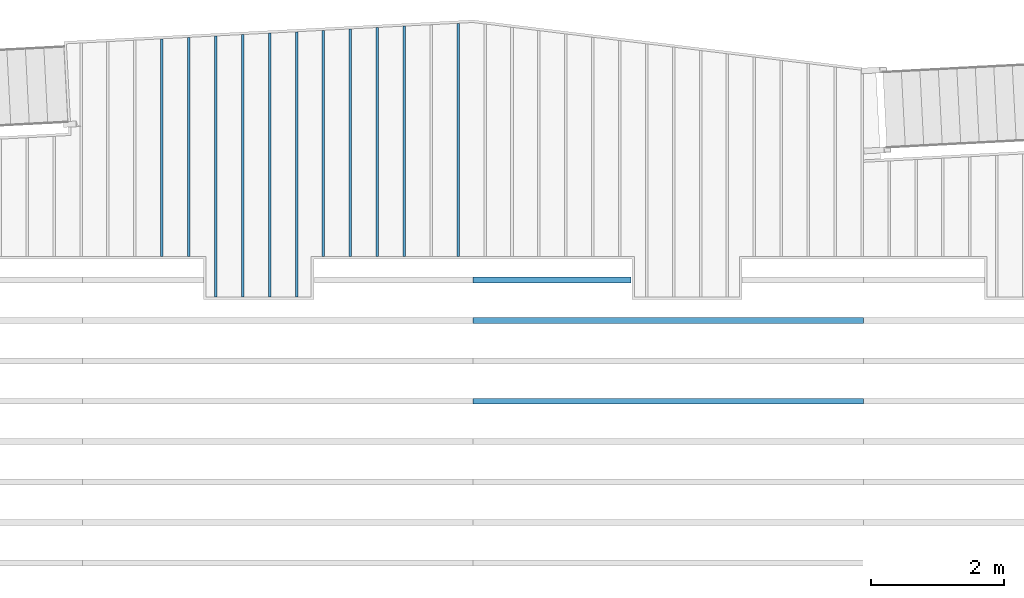
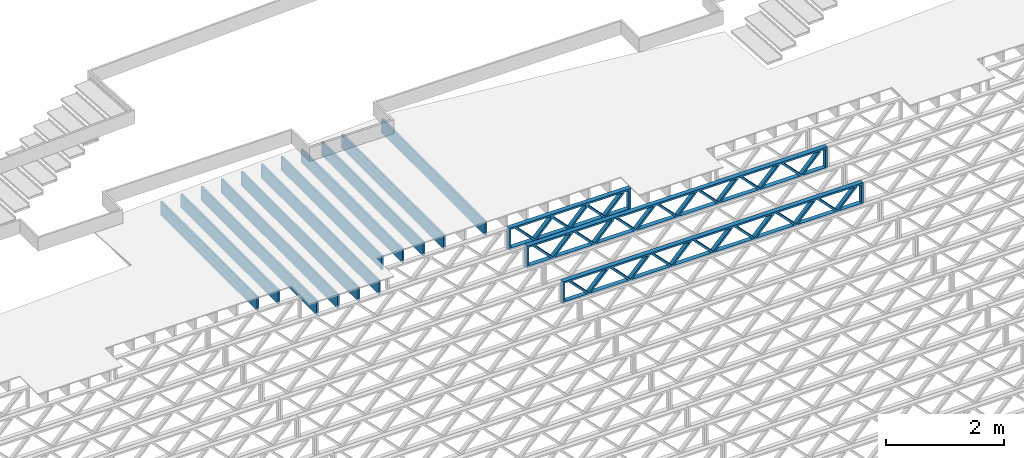
# One storey, part 8 of 23: 14 beams, 2 elements without a shape of their own.
"""IFC4 building model written with IfcOpenShell, lengths in feet."""

from ifc_helpers import new_model, entity, si_unit, converted_unit, derived_unit, direction, frame, frame_2d, origin, origin_2d_with_axis, place, context, subcontext, project, spatial, rectangle, extrude, source, transform, mapped, material, material_profile, profile_set, profile_usage, type_object, type_shapes, element, aggregate, save


model = new_model("IFC4")

# Units and contexts
model_context_1 = context("Model", 3, precision=0.0001, world=origin(), true_north=direction((6.12303176911189e-17, 1.0)))
model_context_2 = context("Model", 3, precision=0.0001, world=origin(), true_north=direction((6.12303176911189e-17, 1.0)))
body_context = subcontext(model_context_2, "Body", "Model", "MODEL_VIEW")
ifc_project = project(units=[converted_unit("LENGTHUNIT", "FOOT", entity("IfcRatioMeasure", 0.3048), si_unit("LENGTHUNIT", "METRE"), dimensions=[1, 0, 0, 0, 0, 0, 0]), converted_unit("AREAUNIT", "SQUARE FOOT", entity("IfcRatioMeasure", 0.09290304), si_unit("AREAUNIT", "SQUARE_METRE"), dimensions=[2, 0, 0, 0, 0, 0, 0]), converted_unit("VOLUMEUNIT", "CUBIC FOOT", entity("IfcRatioMeasure", 0.028316846592), si_unit("VOLUMEUNIT", "CUBIC_METRE"), dimensions=[3, 0, 0, 0, 0, 0, 0]), converted_unit("PLANEANGLEUNIT", "DEGREE", entity("IfcRatioMeasure", 0.0174532925199433), si_unit("PLANEANGLEUNIT", "RADIAN"), dimensions=[0, 0, 0, 0, 0, 0, 0]), si_unit("MASSUNIT", "GRAM", prefix="KILO"), derived_unit("MASSDENSITYUNIT", [(si_unit("MASSUNIT", "GRAM", prefix="KILO"), 1), (si_unit("LENGTHUNIT", "METRE"), -3)]), derived_unit("MOMENTOFINERTIAUNIT", [(si_unit("LENGTHUNIT", "METRE"), 4)]), si_unit("TIMEUNIT", "SECOND"), si_unit("FREQUENCYUNIT", "HERTZ"), si_unit("THERMODYNAMICTEMPERATUREUNIT", "DEGREE_CELSIUS"), derived_unit("THERMALTRANSMITTANCEUNIT", [(si_unit("MASSUNIT", "GRAM", prefix="KILO"), 1), (si_unit("THERMODYNAMICTEMPERATUREUNIT", "KELVIN"), -1), (si_unit("TIMEUNIT", "SECOND"), -3)]), derived_unit("VOLUMETRICFLOWRATEUNIT", [(si_unit("LENGTHUNIT", "METRE"), 3), (si_unit("TIMEUNIT", "SECOND"), -1)]), si_unit("ELECTRICCURRENTUNIT", "AMPERE"), si_unit("ELECTRICVOLTAGEUNIT", "VOLT"), si_unit("POWERUNIT", "WATT"), si_unit("FORCEUNIT", "NEWTON"), si_unit("ILLUMINANCEUNIT", "LUX"), si_unit("LUMINOUSFLUXUNIT", "LUMEN"), si_unit("LUMINOUSINTENSITYUNIT", "CANDELA"), derived_unit("USERDEFINED", [(si_unit("MASSUNIT", "GRAM", prefix="KILO"), -1), (si_unit("LENGTHUNIT", "METRE"), -2), (si_unit("TIMEUNIT", "SECOND"), 3), (si_unit("LUMINOUSFLUXUNIT", "LUMEN"), 1)]), derived_unit("LINEARVELOCITYUNIT", [(si_unit("LENGTHUNIT", "METRE"), 1), (si_unit("TIMEUNIT", "SECOND"), -1)]), si_unit("PRESSUREUNIT", "PASCAL"), derived_unit("USERDEFINED", [(si_unit("LENGTHUNIT", "METRE"), -2), (si_unit("MASSUNIT", "GRAM", prefix="KILO"), 1), (si_unit("TIMEUNIT", "SECOND"), -2)]), derived_unit("LINEARFORCEUNIT", [(si_unit("MASSUNIT", "GRAM", prefix="KILO"), 1), (si_unit("LENGTHUNIT", "METRE"), 1), (si_unit("TIMEUNIT", "SECOND"), -2), (si_unit("LENGTHUNIT", "METRE"), -1)]), derived_unit("PLANARFORCEUNIT", [(si_unit("MASSUNIT", "GRAM", prefix="KILO"), 1), (si_unit("LENGTHUNIT", "METRE"), 1), (si_unit("TIMEUNIT", "SECOND"), -2), (si_unit("LENGTHUNIT", "METRE"), -2)])], contexts=[model_context_1])

# Site, building, storey
site_placement = place(None, origin())
site = spatial("IfcSite", under=ifc_project, at=site_placement, CompositionType="ELEMENT")
building_placement = place(site_placement, origin())
building = spatial("IfcBuilding", under=site, at=building_placement, CompositionType="ELEMENT")
storey_placement = place(building_placement, frame((0.0, 0.0, 10.8020833333333)))
storey = spatial("IfcBuildingStorey", under=building, at=storey_placement, Name="2ND FLOOR", CompositionType="ELEMENT", Elevation=10.8020833333333)

# Assembly, beams
assembly_1_placement = place(storey_placement, origin())
assembly_1 = element("IfcElementAssembly", 1, at=assembly_1_placement, inside=storey, Name="Structural Beam System:Structural Framing System", ObjectType="Structural Beam System:Structural Framing System", AssemblyPlace="NOTDEFINED", PredefinedType="BEAM_GRID")
ifc_material_1 = material(Category="Materials")
ifc_material_profile_1 = material_profile(ifc_material_1, rectangle(XDim=0.9375, YDim=0.125000000000011, at=origin_2d_with_axis()))
ifc_profile_set_1 = profile_set([ifc_material_profile_1])
ifc_profile_usage_1 = profile_usage(ifc_profile_set_1, cardinal=8)
beam_type_1 = type_object("IfcBeamType", PredefinedType="BEAM", material=ifc_profile_set_1)
shared_shape_1 = source(origin(), body_context, "Body", "SweptSolid", [
    extrude(rectangle(XDim=0.9375, YDim=0.125000000000011, at=origin_2d_with_axis()), frame((-5.77048539423151, 0.0, 0.0), z_axis=(1.0, 0.0, 0.0), x_axis=(0.0, 0.0, -1.0)), (0.0, 0.0, 1.0), 11.540970788463),
])
type_shapes(beam_type_1, [shared_shape_1])
beam_1_placement = place(assembly_1_placement, frame((-203.800660485462, 964.799088042507, -0.729166666666744), z_axis=(0.0, 0.0, 1.0), x_axis=(0.0, 1.0, 0.0)))
beam_1 = element("IfcBeam", 2, at=beam_1_placement, type_object=beam_type_1, material=ifc_profile_usage_1, PredefinedType="BEAM", context=body_context, shape_type="MappedRepresentation", body=[
    mapped(shared_shape_1, transform((0.0, 0.0, 0.0), scale=1.0)),
])
ifc_profile_usage_2 = profile_usage(ifc_profile_set_1, cardinal=8)
beam_type_2 = type_object("IfcBeamType", PredefinedType="BEAM", material=ifc_profile_set_1)
shared_shape_2 = source(origin(), body_context, "Body", "SweptSolid", [
    extrude(rectangle(XDim=0.9375, YDim=0.125000000000011, at=origin_2d_with_axis()), frame((-6.56201740913974, 0.0, 0.0), z_axis=(1.0, 0.0, 0.0), x_axis=(0.0, 0.0, -1.0)), (0.0, 0.0, 1.0), 13.1240348182795),
])
type_shapes(beam_type_2, [shared_shape_2])
beam_2_placement = place(assembly_1_placement, frame((-211.800660485462, 963.590618958458, -0.729166666666744), z_axis=(0.0, 0.0, 1.0), x_axis=(0.0, 1.0, 0.0)))
beam_2 = element("IfcBeam", 3, at=beam_2_placement, type_object=beam_type_2, material=ifc_profile_usage_2, PredefinedType="BEAM", context=body_context, shape_type="MappedRepresentation", body=[
    mapped(shared_shape_2, transform((0.0, 0.0, 0.0), scale=1.0)),
])
ifc_profile_usage_3 = profile_usage(ifc_profile_set_1, cardinal=8)
beam_type_3 = type_object("IfcBeamType", PredefinedType="BEAM", material=ifc_profile_set_1)
shared_shape_3 = source(origin(), body_context, "Body", "SweptSolid", [
    extrude(rectangle(XDim=0.9375, YDim=0.125000000000011, at=origin_2d_with_axis()), frame((-6.52727265337796, 0.0, 0.0), z_axis=(1.0, 0.0, 0.0), x_axis=(0.0, 0.0, -1.0)), (0.0, 0.0, 1.0), 13.0545453067559),
])
type_shapes(beam_type_3, [shared_shape_3])
beam_3_placement = place(assembly_1_placement, frame((-213.133993818795, 963.555874202696, -0.729166666666744), z_axis=(0.0, 0.0, 1.0), x_axis=(0.0, 1.0, 0.0)))
beam_3 = element("IfcBeam", 4, at=beam_3_placement, type_object=beam_type_3, material=ifc_profile_usage_3, PredefinedType="BEAM", context=body_context, shape_type="MappedRepresentation", body=[
    mapped(shared_shape_3, transform((0.0, 0.0, 0.0), scale=1.0)),
])
ifc_profile_usage_4 = profile_usage(ifc_profile_set_1, cardinal=8)
beam_type_4 = type_object("IfcBeamType", PredefinedType="BEAM", material=ifc_profile_set_1)
shared_shape_4 = source(origin(), body_context, "Body", "SweptSolid", [
    extrude(rectangle(XDim=0.9375, YDim=0.125000000000011, at=origin_2d_with_axis()), frame((-6.49252789761618, 0.0, 0.0), z_axis=(1.0, 0.0, 0.0), x_axis=(0.0, 0.0, -1.0)), (0.0, 0.0, 1.0), 12.9850557952324),
])
type_shapes(beam_type_4, [shared_shape_4])
beam_4_placement = place(assembly_1_placement, frame((-214.467327152129, 963.521129446934, -0.729166666666744), z_axis=(0.0, 0.0, 1.0), x_axis=(0.0, 1.0, 0.0)))
beam_4 = element("IfcBeam", 5, at=beam_4_placement, type_object=beam_type_4, material=ifc_profile_usage_4, PredefinedType="BEAM", context=body_context, shape_type="MappedRepresentation", body=[
    mapped(shared_shape_4, transform((0.0, 0.0, 0.0), scale=1.0)),
])
ifc_profile_usage_5 = profile_usage(ifc_profile_set_1, cardinal=8)
beam_type_5 = type_object("IfcBeamType", PredefinedType="BEAM", material=ifc_profile_set_1)
shared_shape_5 = source(origin(), body_context, "Body", "SweptSolid", [
    extrude(rectangle(XDim=0.9375, YDim=0.125000000000011, at=origin_2d_with_axis()), frame((-5.38829312204956, 0.0, 0.0), z_axis=(1.0, 0.0, 0.0), x_axis=(0.0, 0.0, -1.0)), (0.0, 0.0, 1.0), 10.7765862440991),
])
type_shapes(beam_type_5, [shared_shape_5])
beam_5_placement = place(assembly_1_placement, frame((-218.467327152129, 964.41689568793, -0.729166666666744), z_axis=(0.0, 0.0, 1.0), x_axis=(0.0, 1.0, 0.0)))
beam_5 = element("IfcBeam", 6, at=beam_5_placement, type_object=beam_type_5, material=ifc_profile_usage_5, PredefinedType="BEAM", context=body_context, shape_type="MappedRepresentation", body=[
    mapped(shared_shape_5, transform((0.0, 0.0, 0.0), scale=1.0)),
])

assembly_2_placement = place(storey_placement, origin())
assembly_2 = element("IfcElementAssembly", 7, at=assembly_2_placement, inside=storey, Name="Structural Beam System:Structural Framing System", ObjectType="Structural Beam System:Structural Framing System", AssemblyPlace="NOTDEFINED", PredefinedType="BEAM_GRID")
ifc_material_2 = material(Name="WOOD TRUSS", Category="Materials")
ifc_material_profile_2 = material_profile(ifc_material_2, rectangle(XDim=1.73473973950632, YDim=0.125, at=frame_2d((-1.11022302462516e-16, 8.32667268468867e-17), x_axis=(1.0, 0.0))))
ifc_material_profile_3 = material_profile(ifc_material_2, rectangle(XDim=1.73473973950633, YDim=0.125, at=frame_2d((-1.11022302462516e-16, 8.32667268468867e-17), x_axis=(1.0, 0.0))))
ifc_material_profile_4 = material_profile(ifc_material_2, rectangle(XDim=1.73473973950632, YDim=0.125, at=frame_2d((-5.55111512312578e-17, 1.38777878078145e-16), x_axis=(1.0, 0.0))))
ifc_material_profile_5 = material_profile(ifc_material_2, rectangle(XDim=1.73473973950633, YDim=0.125, at=frame_2d((-1.11022302462516e-16, 8.32667268468867e-17), x_axis=(1.0, 0.0))))
ifc_material_profile_6 = material_profile(ifc_material_2, rectangle(XDim=1.73473973950632, YDim=0.125, at=frame_2d((-1.11022302462516e-16, 8.32667268468867e-17), x_axis=(1.0, 0.0))))
ifc_material_profile_7 = material_profile(ifc_material_2, rectangle(XDim=1.73473973950633, YDim=0.125, at=frame_2d((-2.77555756156289e-16, 3.05311331771918e-16), x_axis=(1.0, 0.0))))
ifc_material_profile_8 = material_profile(ifc_material_2, rectangle(XDim=1.73473973950632, YDim=0.124999999999999, at=frame_2d((-3.88578058618805e-16, -2.4980018054066e-16), x_axis=(1.0, 0.0))))
ifc_material_profile_9 = material_profile(ifc_material_2, rectangle(XDim=1.73473973950633, YDim=0.125, at=frame_2d((2.77555756156289e-16, -3.05311331771918e-16), x_axis=(1.0, 0.0))))
ifc_material_profile_10 = material_profile(ifc_material_2, rectangle(XDim=1.73473973950632, YDim=0.124999999999999, at=frame_2d((-1.11022302462516e-16, 8.32667268468867e-17), x_axis=(1.0, 0.0))))
ifc_material_profile_11 = material_profile(ifc_material_2, rectangle(XDim=1.73473973950633, YDim=0.125, at=origin_2d_with_axis()))
ifc_material_profile_12 = material_profile(ifc_material_2, rectangle(XDim=0.124999999999982, YDim=0.291666666666668, at=origin_2d_with_axis()))
ifc_material_profile_13 = material_profile(ifc_material_2, rectangle(XDim=0.124999999999932, YDim=0.291666666666664, at=origin_2d_with_axis()))
ifc_material_profile_14 = material_profile(ifc_material_2, rectangle(XDim=1.25000000000002, YDim=0.29166666666667, at=origin_2d_with_axis()))
ifc_material_profile_15 = material_profile(ifc_material_2, rectangle(XDim=1.25000000000004, YDim=0.291666666666667, at=origin_2d_with_axis()))
ifc_profile_set_2 = profile_set([ifc_material_profile_2, ifc_material_profile_3, ifc_material_profile_4, ifc_material_profile_5, ifc_material_profile_6, ifc_material_profile_7, ifc_material_profile_8, ifc_material_profile_9, ifc_material_profile_10, ifc_material_profile_11, ifc_material_profile_12, ifc_material_profile_13, ifc_material_profile_14, ifc_material_profile_15])
ifc_profile_usage_6 = profile_usage(ifc_profile_set_2, cardinal=8)
beam_type_6 = type_object("IfcBeamType", PredefinedType="BEAM", material=ifc_profile_set_2)
shared_shape_6 = source(origin(), body_context, "Body", "SweptSolid", [
    extrude(rectangle(XDim=1.73473973950632, YDim=0.124999999999999, at=frame_2d((5.55111512312578e-16, 7.21644966006352e-16), x_axis=(1.0, 0.0))), frame((5.95847627016989, -0.145833333333334, 0.0), z_axis=(0.0, 1.0, 0.0), x_axis=(0.693383046997606, 0.0, 0.720569184836762)), (0.0, 0.0, 1.0), 0.291666666666667),
    extrude(rectangle(XDim=1.73473973950633, YDim=0.125, at=origin_2d_with_axis()), frame((4.70819039649662, -0.145833333333334, 0.0), z_axis=(0.0, 1.0, 0.0), x_axis=(0.69338304699761, 0.0, -0.720569184836758)), (0.0, 0.0, 1.0), 0.291666666666666),
    extrude(rectangle(XDim=1.73473973950632, YDim=0.125, at=frame_2d((2.22044604925031e-16, 3.88578058618805e-16), x_axis=(1.0, 0.0))), frame((3.29180960350342, -0.145833333333334, 0.0), z_axis=(0.0, 1.0, 0.0), x_axis=(0.693383046997606, 0.0, 0.720569184836762)), (0.0, 0.0, 1.0), 0.291666666666667),
    extrude(rectangle(XDim=1.73473973950633, YDim=0.125, at=frame_2d((1.11022302462516e-16, -8.32667268468867e-17), x_axis=(1.0, 0.0))), frame((2.04152372983015, -0.145833333333334, 0.0), z_axis=(0.0, 1.0, 0.0), x_axis=(0.69338304699761, 0.0, -0.720569184836758)), (0.0, 0.0, 1.0), 0.291666666666667),
    extrude(rectangle(XDim=1.73473973950632, YDim=0.125, at=frame_2d((-5.55111512312578e-17, 1.38777878078145e-16), x_axis=(1.0, 0.0))), frame((0.625142936836964, -0.145833333333334, 0.0), z_axis=(0.0, 1.0, 0.0), x_axis=(0.693383046997606, 0.0, 0.720569184836762)), (0.0, 0.0, 1.0), 0.291666666666667),
    extrude(rectangle(XDim=1.73473973950633, YDim=0.125, at=frame_2d((-1.11022302462516e-16, 8.32667268468867e-17), x_axis=(1.0, 0.0))), frame((-0.625142936836306, -0.145833333333334, 0.0), z_axis=(0.0, 1.0, 0.0), x_axis=(0.69338304699761, 0.0, -0.720569184836758)), (0.0, 0.0, 1.0), 0.291666666666667),
    extrude(rectangle(XDim=1.73473973950632, YDim=0.125, at=frame_2d((-1.11022302462516e-16, 8.32667268468867e-17), x_axis=(1.0, 0.0))), frame((-2.0415237298295, -0.145833333333334, 0.0), z_axis=(0.0, 1.0, 0.0), x_axis=(0.693383046997606, 0.0, 0.720569184836762)), (0.0, 0.0, 1.0), 0.291666666666667),
    extrude(rectangle(XDim=1.73473973950633, YDim=0.125, at=origin_2d_with_axis()), frame((-3.29180960350277, -0.145833333333334, 0.0), z_axis=(0.0, 1.0, 0.0), x_axis=(0.69338304699761, 0.0, -0.720569184836758)), (0.0, 0.0, 1.0), 0.291666666666667),
    extrude(rectangle(XDim=1.73473973950632, YDim=0.124999999999999, at=frame_2d((-1.11022302462516e-16, 8.32667268468867e-17), x_axis=(1.0, 0.0))), frame((-4.70819039649596, -0.145833333333334, 0.0), z_axis=(0.0, 1.0, 0.0), x_axis=(0.693383046997606, 0.0, 0.720569184836762)), (0.0, 0.0, 1.0), 0.291666666666667),
    extrude(rectangle(XDim=1.73473973950633, YDim=0.125, at=frame_2d((-5.55111512312578e-16, 6.38378239159465e-16), x_axis=(1.0, 0.0))), frame((-5.95847627016923, -0.145833333333334, 0.0), z_axis=(0.0, 1.0, 0.0), x_axis=(0.69338304699761, 0.0, -0.720569184836758)), (0.0, 0.0, 1.0), 0.291666666666666),
    extrude(rectangle(XDim=1.73473973950632, YDim=0.125, at=frame_2d((-7.21644966006352e-16, -5.82867087928207e-16), x_axis=(1.0, 0.0))), frame((8.62514293683635, -0.145833333333334, 0.0), z_axis=(0.0, 1.0, 0.0), x_axis=(0.693383046997607, 0.0, 0.720569184836761)), (0.0, 0.0, 1.0), 0.291666666666667),
    extrude(rectangle(XDim=1.73473973950633, YDim=0.125, at=origin_2d_with_axis()), frame((7.37485706316307, -0.145833333333334, 0.0), z_axis=(0.0, 1.0, 0.0), x_axis=(0.69338304699761, 0.0, -0.720569184836758)), (0.0, 0.0, 1.0), 0.291666666666666),
    extrude(rectangle(XDim=1.73473973950632, YDim=0.124999999999999, at=frame_2d((-1.11022302462516e-16, 8.32667268468867e-17), x_axis=(1.0, 0.0))), frame((-7.37485706316242, -0.145833333333334, 0.0), z_axis=(0.0, 1.0, 0.0), x_axis=(0.693383046997606, 0.0, 0.720569184836762)), (0.0, 0.0, 1.0), 0.291666666666667),
    extrude(rectangle(XDim=1.73473973950633, YDim=0.125, at=origin_2d_with_axis()), frame((-8.62514293683569, -0.145833333333334, 0.0), z_axis=(0.0, 1.0, 0.0), x_axis=(0.69338304699761, 0.0, -0.720569184836758)), (0.0, 0.0, 1.0), 0.291666666666666),
    extrude(rectangle(XDim=0.124999999999982, YDim=0.291666666666668, at=origin_2d_with_axis()), frame((-9.66666666666596, 0.0, 0.687500000000054), z_axis=(1.0, 0.0, 0.0), x_axis=(0.0, 0.0, -1.0)), (0.0, 0.0, 1.0), 19.3333333333319),
    extrude(rectangle(XDim=0.124999999999932, YDim=0.291666666666664, at=origin_2d_with_axis()), frame((-9.66666666666575, 0.0, -0.687499999999984), z_axis=(1.0, 0.0, 0.0), x_axis=(0.0, 0.0, -1.0)), (0.0, 0.0, 1.0), 19.3333333333317),
    extrude(rectangle(XDim=1.25000000000002, YDim=0.29166666666667, at=origin_2d_with_axis()), frame((9.54166666666594, 0.0, 0.0), z_axis=(1.0, 0.0, 0.0), x_axis=(0.0, 0.0, -1.0)), (0.0, 0.0, 1.0), 0.12500000000002),
    extrude(rectangle(XDim=1.25000000000004, YDim=0.291666666666667, at=origin_2d_with_axis()), frame((-9.66666666666596, 0.0, 0.0), z_axis=(1.0, 0.0, 0.0), x_axis=(0.0, 0.0, -1.0)), (0.0, 0.0, 1.0), 0.125000000000023),
])
type_shapes(beam_type_6, [shared_shape_6])
beam_6_placement = place(assembly_2_placement, frame((-193.404827152229, 955.861934882651, -0.947916666666881)))
beam_6 = element("IfcBeam", 8, at=beam_6_placement, type_object=beam_type_6, material=ifc_profile_usage_6, PredefinedType="BEAM", context=body_context, shape_type="MappedRepresentation", body=[
    mapped(shared_shape_6, transform((0.0, 0.0, 0.0), scale=1.0)),
])
ifc_profile_usage_7 = profile_usage(ifc_profile_set_2, cardinal=8)
beam_type_7 = type_object("IfcBeamType", PredefinedType="BEAM", material=ifc_profile_set_2)
shared_shape_7 = source(origin(), body_context, "Body", "SweptSolid", [
    extrude(rectangle(XDim=1.73473973950632, YDim=0.124999999999999, at=frame_2d((5.55111512312578e-16, 7.21644966006352e-16), x_axis=(1.0, 0.0))), frame((5.95847627016997, -0.145833333333334, 0.0), z_axis=(0.0, 1.0, 0.0), x_axis=(0.693383046997606, 0.0, 0.720569184836762)), (0.0, 0.0, 1.0), 0.291666666666667),
    extrude(rectangle(XDim=1.73473973950633, YDim=0.125, at=origin_2d_with_axis()), frame((4.7081903964967, -0.145833333333334, 0.0), z_axis=(0.0, 1.0, 0.0), x_axis=(0.69338304699761, 0.0, -0.720569184836758)), (0.0, 0.0, 1.0), 0.291666666666666),
    extrude(rectangle(XDim=1.73473973950632, YDim=0.125, at=frame_2d((2.22044604925031e-16, 3.88578058618805e-16), x_axis=(1.0, 0.0))), frame((3.29180960350347, -0.145833333333334, 0.0), z_axis=(0.0, 1.0, 0.0), x_axis=(0.693383046997606, 0.0, 0.720569184836762)), (0.0, 0.0, 1.0), 0.291666666666667),
    extrude(rectangle(XDim=1.73473973950633, YDim=0.125, at=frame_2d((1.11022302462516e-16, -8.32667268468867e-17), x_axis=(1.0, 0.0))), frame((2.0415237298302, -0.145833333333334, 0.0), z_axis=(0.0, 1.0, 0.0), x_axis=(0.69338304699761, 0.0, -0.720569184836758)), (0.0, 0.0, 1.0), 0.291666666666667),
    extrude(rectangle(XDim=1.73473973950632, YDim=0.125, at=frame_2d((-5.55111512312578e-17, 1.38777878078145e-16), x_axis=(1.0, 0.0))), frame((0.625142936836964, -0.145833333333334, 0.0), z_axis=(0.0, 1.0, 0.0), x_axis=(0.693383046997606, 0.0, 0.720569184836762)), (0.0, 0.0, 1.0), 0.291666666666667),
    extrude(rectangle(XDim=1.73473973950633, YDim=0.125, at=frame_2d((-1.11022302462516e-16, 8.32667268468867e-17), x_axis=(1.0, 0.0))), frame((-0.625142936836306, -0.145833333333334, 0.0), z_axis=(0.0, 1.0, 0.0), x_axis=(0.69338304699761, 0.0, -0.720569184836758)), (0.0, 0.0, 1.0), 0.291666666666667),
    extrude(rectangle(XDim=1.73473973950632, YDim=0.125, at=frame_2d((-1.11022302462516e-16, 8.32667268468867e-17), x_axis=(1.0, 0.0))), frame((-2.04152372982954, -0.145833333333334, 0.0), z_axis=(0.0, 1.0, 0.0), x_axis=(0.693383046997606, 0.0, 0.720569184836762)), (0.0, 0.0, 1.0), 0.291666666666667),
    extrude(rectangle(XDim=1.73473973950633, YDim=0.125, at=origin_2d_with_axis()), frame((-3.29180960350281, -0.145833333333334, 0.0), z_axis=(0.0, 1.0, 0.0), x_axis=(0.69338304699761, 0.0, -0.720569184836758)), (0.0, 0.0, 1.0), 0.291666666666667),
    extrude(rectangle(XDim=1.73473973950632, YDim=0.124999999999999, at=frame_2d((-1.11022302462516e-16, 8.32667268468867e-17), x_axis=(1.0, 0.0))), frame((-4.70819039649604, -0.145833333333334, 0.0), z_axis=(0.0, 1.0, 0.0), x_axis=(0.693383046997606, 0.0, 0.720569184836762)), (0.0, 0.0, 1.0), 0.291666666666667),
    extrude(rectangle(XDim=1.73473973950633, YDim=0.125, at=frame_2d((-5.55111512312578e-16, 6.38378239159465e-16), x_axis=(1.0, 0.0))), frame((-5.95847627016931, -0.145833333333334, 0.0), z_axis=(0.0, 1.0, 0.0), x_axis=(0.69338304699761, 0.0, -0.720569184836758)), (0.0, 0.0, 1.0), 0.291666666666666),
    extrude(rectangle(XDim=1.73473973950632, YDim=0.125, at=frame_2d((-7.21644966006352e-16, -5.82867087928207e-16), x_axis=(1.0, 0.0))), frame((8.62514293683647, -0.145833333333334, 0.0), z_axis=(0.0, 1.0, 0.0), x_axis=(0.693383046997607, 0.0, 0.720569184836761)), (0.0, 0.0, 1.0), 0.291666666666667),
    extrude(rectangle(XDim=1.73473973950633, YDim=0.125, at=origin_2d_with_axis()), frame((7.3748570631632, -0.145833333333334, 0.0), z_axis=(0.0, 1.0, 0.0), x_axis=(0.69338304699761, 0.0, -0.720569184836758)), (0.0, 0.0, 1.0), 0.291666666666666),
    extrude(rectangle(XDim=1.73473973950632, YDim=0.124999999999999, at=frame_2d((-1.11022302462516e-16, 8.32667268468867e-17), x_axis=(1.0, 0.0))), frame((-7.37485706316255, -0.145833333333334, 0.0), z_axis=(0.0, 1.0, 0.0), x_axis=(0.693383046997606, 0.0, 0.720569184836762)), (0.0, 0.0, 1.0), 0.291666666666667),
    extrude(rectangle(XDim=1.73473973950633, YDim=0.125, at=origin_2d_with_axis()), frame((-8.62514293683582, -0.145833333333334, 0.0), z_axis=(0.0, 1.0, 0.0), x_axis=(0.69338304699761, 0.0, -0.720569184836758)), (0.0, 0.0, 1.0), 0.291666666666666),
    extrude(rectangle(XDim=0.124999999999982, YDim=0.291666666666668, at=origin_2d_with_axis()), frame((-9.66666666666609, 0.0, 0.687500000000054), z_axis=(1.0, 0.0, 0.0), x_axis=(0.0, 0.0, -1.0)), (0.0, 0.0, 1.0), 19.3333333333322),
    extrude(rectangle(XDim=0.124999999999932, YDim=0.291666666666664, at=origin_2d_with_axis()), frame((-9.66666666666588, 0.0, -0.687499999999984), z_axis=(1.0, 0.0, 0.0), x_axis=(0.0, 0.0, -1.0)), (0.0, 0.0, 1.0), 19.333333333332),
    extrude(rectangle(XDim=1.25000000000002, YDim=0.29166666666667, at=origin_2d_with_axis()), frame((9.54166666666607, 0.0, 0.0), z_axis=(1.0, 0.0, 0.0), x_axis=(0.0, 0.0, -1.0)), (0.0, 0.0, 1.0), 0.12500000000002),
    extrude(rectangle(XDim=1.25000000000004, YDim=0.291666666666667, at=origin_2d_with_axis()), frame((-9.66666666666609, 0.0, 0.0), z_axis=(1.0, 0.0, 0.0), x_axis=(0.0, 0.0, -1.0)), (0.0, 0.0, 1.0), 0.125000000000023),
])
type_shapes(beam_type_7, [shared_shape_7])
beam_7_placement = place(assembly_2_placement, frame((-193.404827152229, 951.861934882651, -0.947916666666881)))
beam_7 = element("IfcBeam", 9, at=beam_7_placement, type_object=beam_type_7, material=ifc_profile_usage_7, PredefinedType="BEAM", context=body_context, shape_type="MappedRepresentation", body=[
    mapped(shared_shape_7, transform((0.0, 0.0, 0.0), scale=1.0)),
])

# Beam
ifc_profile_usage_8 = profile_usage(ifc_profile_set_1, cardinal=8)
beam_type_8 = type_object("IfcBeamType", PredefinedType="BEAM", material=ifc_profile_set_1)
shared_shape_8 = source(origin(), body_context, "Body", "SweptSolid", [
    extrude(rectangle(XDim=0.9375, YDim=0.125000000000011, at=origin_2d_with_axis()), frame((-5.59676245292826, 0.0, 0.0), z_axis=(1.0, 0.0, 0.0), x_axis=(0.0, 0.0, -1.0)), (0.0, 0.0, 1.0), 11.1935249058565),
])
type_shapes(beam_type_8, [shared_shape_8])
beam_8_placement = place(assembly_1_placement, frame((-210.467327152129, 964.625363426193, -0.729166666666744), z_axis=(0.0, 0.0, 1.0), x_axis=(0.0, 1.0, 0.0)))
beam_8 = element("IfcBeam", 10, at=beam_8_placement, type_object=beam_type_8, material=ifc_profile_usage_8, PredefinedType="BEAM", context=body_context, shape_type="MappedRepresentation", body=[
    mapped(shared_shape_8, transform((0.0, 0.0, 0.0), scale=1.0)),
])

ifc_profile_usage_9 = profile_usage(ifc_profile_set_1, cardinal=8)
beam_type_9 = type_object("IfcBeamType", PredefinedType="BEAM", material=ifc_profile_set_1)
shared_shape_9 = source(origin(), body_context, "Body", "SweptSolid", [
    extrude(rectangle(XDim=0.9375, YDim=0.125000000000011, at=origin_2d_with_axis()), frame((-5.42303803630836, 0.0, 0.0), z_axis=(1.0, 0.0, 0.0), x_axis=(0.0, 0.0, -1.0)), (0.0, 0.0, 1.0), 10.8460760726167),
])
type_shapes(beam_type_9, [shared_shape_9])
beam_9_placement = place(assembly_1_placement, frame((-217.133993818795, 964.451640285195, -0.729166666666744), z_axis=(0.0, 0.0, 1.0), x_axis=(0.0, 1.0, 0.0)))
beam_9 = element("IfcBeam", 11, at=beam_9_placement, type_object=beam_type_9, material=ifc_profile_usage_9, PredefinedType="BEAM", context=body_context, shape_type="MappedRepresentation", body=[
    mapped(shared_shape_9, transform((0.0, 0.0, 0.0), scale=1.0)),
])

ifc_profile_usage_10 = profile_usage(ifc_profile_set_1, cardinal=8)
beam_type_10 = type_object("IfcBeamType", PredefinedType="BEAM", material=ifc_profile_set_1)
shared_shape_10 = source(origin(), body_context, "Body", "SweptSolid", [
    extrude(rectangle(XDim=0.9375, YDim=0.125000000000011, at=origin_2d_with_axis()), frame((-6.45778314185435, 0.0, 0.0), z_axis=(1.0, 0.0, 0.0), x_axis=(0.0, 0.0, -1.0)), (0.0, 0.0, 1.0), 12.9155662837087),
])
type_shapes(beam_type_10, [shared_shape_10])
beam_10_placement = place(assembly_1_placement, frame((-215.800660485462, 963.486384691172, -0.729166666666744), z_axis=(0.0, 0.0, 1.0), x_axis=(0.0, 1.0, 0.0)))
beam_10 = element("IfcBeam", 12, at=beam_10_placement, type_object=beam_type_10, material=ifc_profile_usage_10, PredefinedType="BEAM", context=body_context, shape_type="MappedRepresentation", body=[
    mapped(shared_shape_10, transform((0.0, 0.0, 0.0), scale=1.0)),
])

ifc_profile_usage_11 = profile_usage(ifc_profile_set_1, cardinal=8)
beam_type_11 = type_object("IfcBeamType", PredefinedType="BEAM", material=ifc_profile_set_1)
shared_shape_11 = source(origin(), body_context, "Body", "SweptSolid", [
    extrude(rectangle(XDim=0.9375, YDim=0.125000000000011, at=origin_2d_with_axis()), frame((-5.63150704118897, 0.0, 0.0), z_axis=(1.0, 0.0, 0.0), x_axis=(0.0, 0.0, -1.0)), (0.0, 0.0, 1.0), 11.2630140823779),
])
type_shapes(beam_type_11, [shared_shape_11])
beam_11_placement = place(assembly_1_placement, frame((-209.133993818795, 964.660108349456, -0.729166666666744), z_axis=(0.0, 0.0, 1.0), x_axis=(0.0, 1.0, 0.0)))
beam_11 = element("IfcBeam", 13, at=beam_11_placement, type_object=beam_type_11, material=ifc_profile_usage_11, PredefinedType="BEAM", context=body_context, shape_type="MappedRepresentation", body=[
    mapped(shared_shape_11, transform((0.0, 0.0, 0.0), scale=1.0)),
])

ifc_profile_usage_12 = profile_usage(ifc_profile_set_1, cardinal=8)
beam_type_12 = type_object("IfcBeamType", PredefinedType="BEAM", material=ifc_profile_set_1)
shared_shape_12 = source(origin(), body_context, "Body", "SweptSolid", [
    extrude(rectangle(XDim=0.9375, YDim=0.125000000000011, at=origin_2d_with_axis()), frame((-5.66625162944956, 0.0, 0.0), z_axis=(1.0, 0.0, 0.0), x_axis=(0.0, 0.0, -1.0)), (0.0, 0.0, 1.0), 11.3325032588991),
])
type_shapes(beam_type_12, [shared_shape_12])
beam_12_placement = place(assembly_1_placement, frame((-207.800660485462, 964.694853272719, -0.729166666666744), z_axis=(0.0, 0.0, 1.0), x_axis=(0.0, 1.0, 0.0)))
beam_12 = element("IfcBeam", 14, at=beam_12_placement, type_object=beam_type_12, material=ifc_profile_usage_12, PredefinedType="BEAM", context=body_context, shape_type="MappedRepresentation", body=[
    mapped(shared_shape_12, transform((0.0, 0.0, 0.0), scale=1.0)),
])

ifc_profile_usage_13 = profile_usage(ifc_profile_set_1, cardinal=8)
beam_type_13 = type_object("IfcBeamType", PredefinedType="BEAM", material=ifc_profile_set_1)
shared_shape_13 = source(origin(), body_context, "Body", "SweptSolid", [
    extrude(rectangle(XDim=0.9375, YDim=0.125000000000011, at=origin_2d_with_axis()), frame((-5.70099621771021, 0.0, 0.0), z_axis=(1.0, 0.0, 0.0), x_axis=(0.0, 0.0, -1.0)), (0.0, 0.0, 1.0), 11.4019924354204),
])
type_shapes(beam_type_13, [shared_shape_13])
beam_13_placement = place(assembly_1_placement, frame((-206.467327152129, 964.729598195982, -0.729166666666744), z_axis=(0.0, 0.0, 1.0), x_axis=(0.0, 1.0, 0.0)))
beam_13 = element("IfcBeam", 15, at=beam_13_placement, type_object=beam_type_13, material=ifc_profile_usage_13, PredefinedType="BEAM", context=body_context, shape_type="MappedRepresentation", body=[
    mapped(shared_shape_13, transform((0.0, 0.0, 0.0), scale=1.0)),
])

aggregate(assembly_1, [beam_1, beam_2, beam_3, beam_4, beam_5, beam_8, beam_9, beam_10, beam_11, beam_12, beam_13])

ifc_profile_usage_14 = profile_usage(ifc_profile_set_2, cardinal=8)
beam_type_14 = type_object("IfcBeamType", PredefinedType="BEAM", material=ifc_profile_set_2)
shared_shape_14 = source(origin(), body_context, "Body", "SweptSolid", [
    extrude(rectangle(XDim=1.73473973950632, YDim=0.125, at=frame_2d((-5.55111512312578e-17, 1.38777878078145e-16), x_axis=(1.0, 0.0))), frame((0.625142936836963, -0.145833333333334, 0.0), z_axis=(0.0, 1.0, 0.0), x_axis=(0.693383046997606, 0.0, 0.720569184836762)), (0.0, 0.0, 1.0), 0.291666666666667),
    extrude(rectangle(XDim=1.73473973950633, YDim=0.125, at=frame_2d((-1.11022302462516e-16, 8.32667268468867e-17), x_axis=(1.0, 0.0))), frame((-0.625142936836308, -0.145833333333334, 0.0), z_axis=(0.0, 1.0, 0.0), x_axis=(0.69338304699761, 0.0, -0.720569184836758)), (0.0, 0.0, 1.0), 0.291666666666667),
    extrude(rectangle(XDim=1.73473973950632, YDim=0.125, at=frame_2d((-1.11022302462516e-16, 8.32667268468867e-17), x_axis=(1.0, 0.0))), frame((2.87514285312432, -0.145833333333334, 0.0), z_axis=(0.0, 1.0, 0.0), x_axis=(0.693383046997606, 0.0, 0.720569184836762)), (0.0, 0.0, 1.0), 0.291666666666667),
    extrude(rectangle(XDim=1.73473973950633, YDim=0.125, at=frame_2d((-1.11022302462516e-16, 8.32667268468867e-17), x_axis=(1.0, 0.0))), frame((1.62485697945105, -0.145833333333334, 0.0), z_axis=(0.0, 1.0, 0.0), x_axis=(0.69338304699761, 0.0, -0.720569184836758)), (0.0, 0.0, 1.0), 0.291666666666667),
    extrude(rectangle(XDim=1.73473973950632, YDim=0.125, at=frame_2d((-1.11022302462516e-16, 8.32667268468867e-17), x_axis=(1.0, 0.0))), frame((-1.62485697945039, -0.145833333333334, 0.0), z_axis=(0.0, 1.0, 0.0), x_axis=(0.693383046997606, 0.0, 0.720569184836762)), (0.0, 0.0, 1.0), 0.291666666666667),
    extrude(rectangle(XDim=1.73473973950633, YDim=0.125, at=origin_2d_with_axis()), frame((-2.87514285312366, -0.145833333333334, 0.0), z_axis=(0.0, 1.0, 0.0), x_axis=(0.69338304699761, 0.0, -0.720569184836758)), (0.0, 0.0, 1.0), 0.291666666666667),
    extrude(rectangle(XDim=0.124999999999982, YDim=0.291666666666668, at=origin_2d_with_axis()), frame((-3.91666658295394, 0.0, 0.687500000000054), z_axis=(1.0, 0.0, 0.0), x_axis=(0.0, 0.0, -1.0)), (0.0, 0.0, 1.0), 7.83333316590787),
    extrude(rectangle(XDim=0.124999999999932, YDim=0.291666666666664, at=origin_2d_with_axis()), frame((-3.91666658295372, 0.0, -0.687499999999984), z_axis=(1.0, 0.0, 0.0), x_axis=(0.0, 0.0, -1.0)), (0.0, 0.0, 1.0), 7.83333316590766),
    extrude(rectangle(XDim=1.25000000000002, YDim=0.29166666666667, at=origin_2d_with_axis()), frame((3.79166658295392, 0.0, 0.0), z_axis=(1.0, 0.0, 0.0), x_axis=(0.0, 0.0, -1.0)), (0.0, 0.0, 1.0), 0.12500000000002),
    extrude(rectangle(XDim=1.25000000000004, YDim=0.291666666666667, at=origin_2d_with_axis()), frame((-3.91666658295394, 0.0, 0.0), z_axis=(1.0, 0.0, 0.0), x_axis=(0.0, 0.0, -1.0)), (0.0, 0.0, 1.0), 0.125000000000023),
])
type_shapes(beam_type_14, [shared_shape_14])
beam_14_placement = place(assembly_2_placement, frame((-199.154827235941, 957.861934882651, -0.947916666666881)))
beam_14 = element("IfcBeam", 16, at=beam_14_placement, type_object=beam_type_14, material=ifc_profile_usage_14, PredefinedType="BEAM", context=body_context, shape_type="MappedRepresentation", body=[
    mapped(shared_shape_14, transform((0.0, 0.0, 0.0), scale=1.0)),
])

aggregate(assembly_2, [beam_6, beam_7, beam_14])

save(model, "model.ifc")
